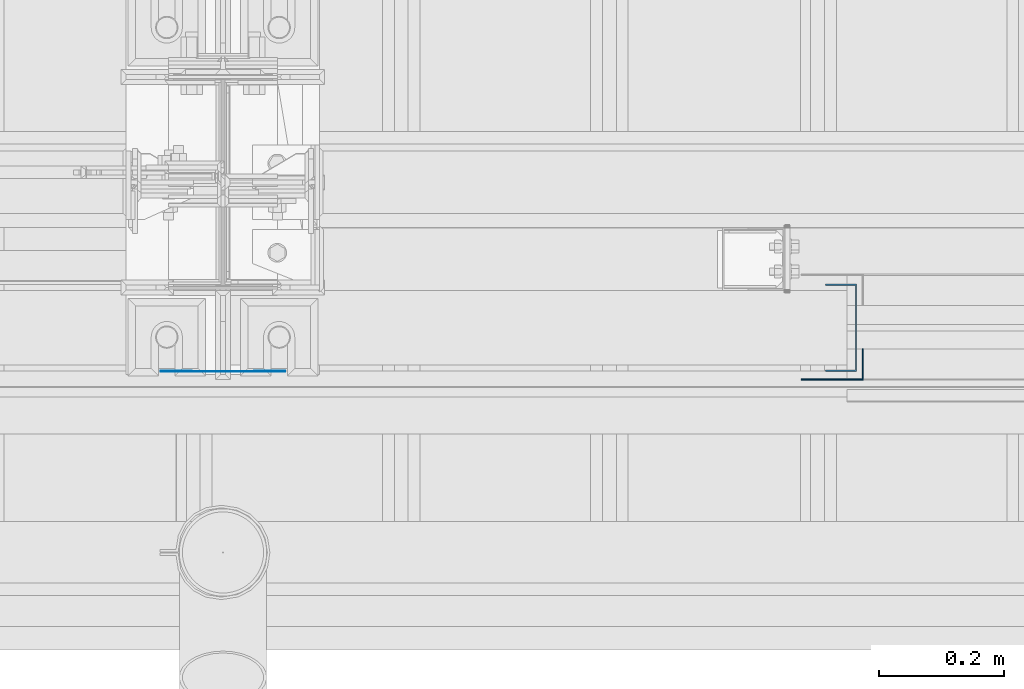
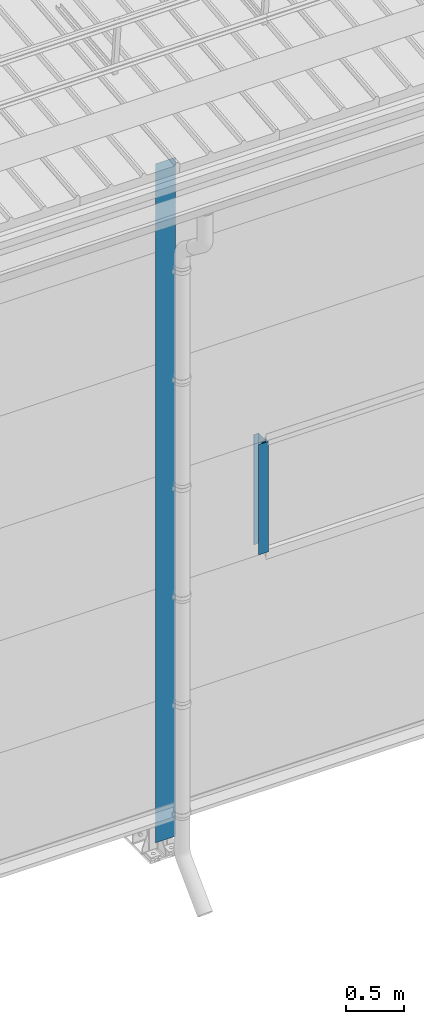
# One storey, part 6 of 709: 3 columns, 3 elements without a shape of their own.
"""IFC4 building model written with IfcOpenShell, lengths in millimetres."""

import ifcopenshell
import ifcopenshell.guid

model = None  # the IFC model being written
_history = None  # IfcOwnerHistory: only IFC2X3 demands one
_inside = {}  # id of a spatial element -> (the spatial element, [elements in it])
_under = {}  # id of a project, library or spatial element -> (it, [spatial elements below it])
_declared = {}  # id of a project -> (the project, [libraries it declares])
_typed = {}  # id of a type object -> (the type object, [elements of that type])
_made_of = {}  # id of a material, layer set ... -> (it, [elements and type objects made of it])


def new_model(schema):
    """Start an empty IFC model of exactly this schema.

    Asked for "IFC4X3", IfcOpenShell would pick the latest addendum, in which some entities
    have other attributes; the version numbers below select the first issue.
    IFC2X3 requires an IfcOwnerHistory on every rooted entity: one is made here for all.
    """
    global model, _history
    if schema == "IFC4X3":
        model = ifcopenshell.file(schema_version=(4, 3, 0, 0))
    else:
        model = ifcopenshell.file(schema=schema)
    _inside.clear()
    _under.clear()
    _declared.clear()
    _typed.clear()
    _made_of.clear()
    _history = None
    if model.schema == "IFC2X3":
        org = make("IfcOrganization", Name="unknown")
        user = make(
            "IfcPersonAndOrganization",
            ThePerson=make("IfcPerson", FamilyName="unknown"),
            TheOrganization=org,
        )
        app = make(
            "IfcApplication",
            ApplicationDeveloper=org,
            Version="unknown",
            ApplicationFullName="unknown",
            ApplicationIdentifier="unknown",
        )
        _history = make(
            "IfcOwnerHistory",
            OwningUser=user,
            OwningApplication=app,
            ChangeAction="ADDED",
            CreationDate=0,
        )
    return model


def make(cls, **values):
    """One entity of the class cls with the attributes given. An attribute that is None is left unset."""
    return model.create_entity(
        cls, **{name: value for name, value in values.items() if value is not None}
    )


def rooted(cls, **values):
    """An entity with a GlobalId (a new one), such as an element, a storey or a relation."""
    return make(cls, GlobalId=ifcopenshell.guid.new(), OwnerHistory=_history, **values)


def si_unit(unit_type, name, prefix=None):
    """IfcSIUnit, for example si_unit("LENGTHUNIT", "METRE", prefix="MILLI")."""
    return make("IfcSIUnit", UnitType=unit_type, Prefix=prefix, Name=name)


def assignment(units):
    """IfcUnitAssignment: the units of a project."""
    return None if units is None else make("IfcUnitAssignment", Units=units)


def point(xyz):
    """IfcCartesianPoint."""
    return None if xyz is None else make("IfcCartesianPoint", Coordinates=xyz)


def direction(xyz):
    """IfcDirection."""
    return None if xyz is None else make("IfcDirection", DirectionRatios=xyz)


def frame(location, z_axis=None, x_axis=None):
    """IfcAxis2Placement3D, a coordinate frame: its origin and axes. An axis left out is left unset."""
    return make(
        "IfcAxis2Placement3D",
        Location=point(location),
        Axis=direction(z_axis),
        RefDirection=direction(x_axis),
    )


def origin_with_axes():
    """The frame at (0, 0, 0) with the z axis (0, 0, 1) and the x axis (1, 0, 0) written out."""
    return frame((0.0, 0.0, 0.0), z_axis=(0.0, 0.0, 1.0), x_axis=(1.0, 0.0, 0.0))


def place(relative_to, where):
    """IfcLocalPlacement: puts the frame where relative to a parent placement (None: the world)."""
    return make(
        "IfcLocalPlacement", PlacementRelTo=relative_to, RelativePlacement=where
    )


def context(
    kind, dimensions, precision=None, world=None, true_north=None, identifier=None
):
    """IfcGeometricRepresentationContext, for example the 3D "Model" context."""
    return make(
        "IfcGeometricRepresentationContext",
        ContextIdentifier=identifier,
        ContextType=kind,
        CoordinateSpaceDimension=dimensions,
        Precision=precision,
        WorldCoordinateSystem=world,
        TrueNorth=true_north,
    )


def subcontext(parent, identifier, kind, view, scale=None):
    """IfcGeometricRepresentationSubContext, for example "Body" below "Model"."""
    return make(
        "IfcGeometricRepresentationSubContext",
        ContextIdentifier=identifier,
        ContextType=kind,
        ParentContext=parent,
        TargetScale=scale,
        TargetView=view,
    )


def project(units=None, contexts=None):
    """IfcProject with its units and contexts."""
    return rooted(
        "IfcProject",
        Name="project",
        RepresentationContexts=contexts,
        UnitsInContext=assignment(units),
    )


def spatial(cls, under=None, at=None, **own):
    """A site, building, storey or space (cls), placed at a placement, below another one or the project."""
    s = rooted(cls, ObjectPlacement=at, **own)
    if under is not None:
        _under.setdefault(under.id(), (under, []))[1].append(s)
    return s


def point_list(points):
    """IfcCartesianPointList2D or 3D."""
    cls = (
        "IfcCartesianPointList2D" if len(points[0]) == 2 else "IfcCartesianPointList3D"
    )
    return make(cls, CoordList=points)


def line(*indices):
    """IfcLineIndex: a straight run through numbered points of an indexed curve."""
    return model.create_entity("IfcLineIndex", indices)


def indexed_curve(points, segments=None, self_intersect=None):
    """IfcIndexedPolyCurve: lines and arcs through numbered points (the first is 1)."""
    return make(
        "IfcIndexedPolyCurve",
        Points=point_list(points),
        Segments=segments,
        SelfIntersect=self_intersect,
    )


def outline(outer, holes=None, kind="AREA"):
    """IfcArbitraryClosedProfileDef: a profile drawn as a closed curve; with holes, ...WithVoids."""
    if holes is None:
        return make("IfcArbitraryClosedProfileDef", ProfileType=kind, OuterCurve=outer)
    return make(
        "IfcArbitraryProfileDefWithVoids",
        ProfileType=kind,
        OuterCurve=outer,
        InnerCurves=holes,
    )


def extrude(swept, where, along, depth):
    """IfcExtrudedAreaSolid: the profile swept, set in the frame where, extruded along a direction by depth."""
    return make(
        "IfcExtrudedAreaSolid",
        SweptArea=swept,
        Position=where,
        ExtrudedDirection=direction(along),
        Depth=depth,
    )


def shape(context_of_items, identifier, shape_type, items):
    """IfcShapeRepresentation: the items that make up one representation, for example the "Body"."""
    return make(
        "IfcShapeRepresentation",
        ContextOfItems=context_of_items,
        RepresentationIdentifier=identifier,
        RepresentationType=shape_type,
        Items=items,
    )


def material(Name=None, Category=None):
    """IfcMaterial."""
    return make("IfcMaterial", Name=Name, Category=Category)


def made_of(thing, what):
    """Note that an element or type object is made of a material, layer set ...; save() writes the relation."""
    if what is not None:
        _made_of.setdefault(what.id(), (what, []))[1].append(thing)
    return thing


def element(
    cls,
    number,
    at=None,
    inside=None,
    cuts=None,
    type_object=None,
    material=None,
    context=None,
    identifier="Body",
    shape_type=None,
    held_by="IfcProductDefinitionShape",
    body=None,
    shapes=None,
    **own,
):
    """One element of the class cls, such as IfcWall. Its Tag is "e" and its number.

    at: its placement. inside: the storey or other place that contains it. cuts: it is an
    opening in that element (IfcRelVoidsElement). A single representation is given by context,
    identifier, shape_type and body (its items); several are given by shapes. held_by: the class
    of the entity that holds the representations. save() writes the other relations.
    """
    e = rooted(cls, Tag="e%d" % number, ObjectPlacement=at, **own)
    if body is not None:
        shapes = [shape(context, identifier, shape_type, body)]
    if shapes is not None:
        e.Representation = make(held_by, Representations=shapes)
    if inside is not None:
        _inside.setdefault(inside.id(), (inside, []))[1].append(e)
    if cuts is not None:
        rooted(
            "IfcRelVoidsElement", RelatingBuildingElement=cuts, RelatedOpeningElement=e
        )
    if type_object is not None:
        _typed.setdefault(type_object.id(), (type_object, []))[1].append(e)
    return made_of(e, material)


def aggregate(whole, parts):
    """IfcRelAggregates: a whole, such as a stair, and the parts it consists of."""
    return rooted("IfcRelAggregates", RelatingObject=whole, RelatedObjects=parts)


def save(model, path):
    """Write the relations noted so far, then the file.

    IfcRelAggregates (storeys below a building ...), IfcRelContainedInSpatialStructure (elements
    in a storey), IfcRelDefinesByType, IfcRelAssociatesMaterial and IfcRelDeclares: one each for
    every whole, place, type object, material and project.
    """
    for whole, parts in _under.values():
        aggregate(whole, parts)
    for where, things in _inside.values():
        rooted(
            "IfcRelContainedInSpatialStructure",
            RelatedElements=things,
            RelatingStructure=where,
        )
    for kind, things in _typed.values():
        rooted("IfcRelDefinesByType", RelatedObjects=things, RelatingType=kind)
    for what, things in _made_of.values():
        rooted("IfcRelAssociatesMaterial", RelatedObjects=things, RelatingMaterial=what)
    for by, libraries in _declared.values():
        rooted("IfcRelDeclares", RelatingContext=by, RelatedDefinitions=libraries)
    model.write(path)


model = new_model("IFC4")

# Units and contexts
model_context = context("Model", 3, precision=0.2, world=origin_with_axes(), true_north=direction((0.0, 1.0)))
body_context = subcontext(model_context, "Body", "Model", "MODEL_VIEW")
ifc_project = project(units=[si_unit("LENGTHUNIT", "METRE", prefix="MILLI"), si_unit("AREAUNIT", "SQUARE_METRE"), si_unit("VOLUMEUNIT", "CUBIC_METRE"), si_unit("MASSUNIT", "GRAM", prefix="KILO"), si_unit("TIMEUNIT", "SECOND"), si_unit("PLANEANGLEUNIT", "RADIAN"), si_unit("SOLIDANGLEUNIT", "STERADIAN"), si_unit("THERMODYNAMICTEMPERATUREUNIT", "DEGREE_CELSIUS"), si_unit("LUMINOUSINTENSITYUNIT", "LUMEN")], contexts=[model_context])

# Site, building, storey
site_placement = place(None, origin_with_axes())
site = spatial("IfcSite", under=ifc_project, at=site_placement, CompositionType="ELEMENT")
building_placement = place(site_placement, origin_with_axes())
building = spatial("IfcBuilding", under=site, at=building_placement, Name="Undefined", CompositionType="ELEMENT")
storey_placement = place(building_placement, origin_with_axes())
storey = spatial("IfcBuildingStorey", under=building, at=storey_placement, Name="Undefined", CompositionType="ELEMENT", Elevation=0.0)

# Assembly, column
assembly_1_placement = place(storey_placement, frame((28990.0, -60.0, 2700.0), z_axis=(0.0, 1.0, 0.0), x_axis=(0.0, 0.0, 1.0)))
assembly_1 = element("IfcElementAssembly", 1, at=assembly_1_placement, inside=storey)
ifc_material = material(Name="Steel_Undefined", Category="STEEL")
column_1_placement = place(assembly_1_placement, origin_with_axes())
column_1 = element("IfcColumn", 2, at=column_1_placement, material=ifc_material, context=body_context, shape_type="SolidModel", body=[
    extrude(outline(indexed_curve([(-70.0, -25.0), (-68.0, -25.0), (-68.0, 23.0), (68.0, 23.0), (68.0, -25.0), (70.0, -25.0), (70.0, 25.0), (-70.0, 25.0)], segments=[line(1, 2, 3, 4, 5, 6, 7, 8, 1)])), frame((0.0, 0.0, 0.0), z_axis=(-1.0, 0.0, 0.0), x_axis=(0.0, 0.0, 1.0)), (0.0, 0.0, -1.0), 1170.0),
])
aggregate(assembly_1, [column_1])

assembly_2_placement = place(storey_placement, frame((29025.0, -119.0, 2700.0), z_axis=(0.0, -1.0, 0.0), x_axis=(0.0, 0.0, 1.0)))
assembly_2 = element("IfcElementAssembly", 3, at=assembly_2_placement, inside=storey)
column_2_placement = place(assembly_2_placement, origin_with_axes())
column_2 = element("IfcColumn", 4, at=column_2_placement, material=ifc_material, context=body_context, shape_type="SolidModel", body=[
    extrude(outline(indexed_curve([(-25.0, -1.0), (25.0, -1.0), (25.0, 99.0), (23.0, 99.0), (23.0, 1.0), (-25.0, 1.0)], segments=[line(1, 2, 3, 4, 5, 6, 1)])), frame((0.0, 0.0, 0.0), z_axis=(-1.0, 0.0, 0.0), x_axis=(0.0, 0.0, 1.0)), (0.0, 0.0, -1.0), 1170.0),
])
aggregate(assembly_2, [column_2])

assembly_3_placement = place(storey_placement, frame((28000.0, -130.0, 0.0), z_axis=(0.0, 1.0, 0.0), x_axis=(0.0, 0.0, 1.0)))
assembly_3 = element("IfcElementAssembly", 5, at=assembly_3_placement, inside=storey)
column_3_placement = place(assembly_3_placement, origin_with_axes())
column_3 = element("IfcColumn", 6, at=column_3_placement, material=ifc_material, context=body_context, shape_type="SolidModel", body=[
    extrude(outline(indexed_curve([(-0.375, -100.0), (1.245, -100.0), (1.245, -50.0), (0.495, -50.0), (0.495, -99.25), (0.375, -99.25), (0.375, 99.25), (0.495, 99.25), (0.495, 50.0), (1.245, 50.0), (1.245, 100.0), (-0.375, 100.0)], segments=[line(1, 2, 3, 4, 5, 6, 7, 8, 9, 10, 11, 12, 1)])), frame((0.0, 0.0, 0.0), z_axis=(-1.0, 0.0, 0.0), x_axis=(0.0, 0.0, 1.0)), (0.0, 0.0, -1.0), 7196.92297),
])
aggregate(assembly_3, [column_3])

save(model, "model.ifc")
